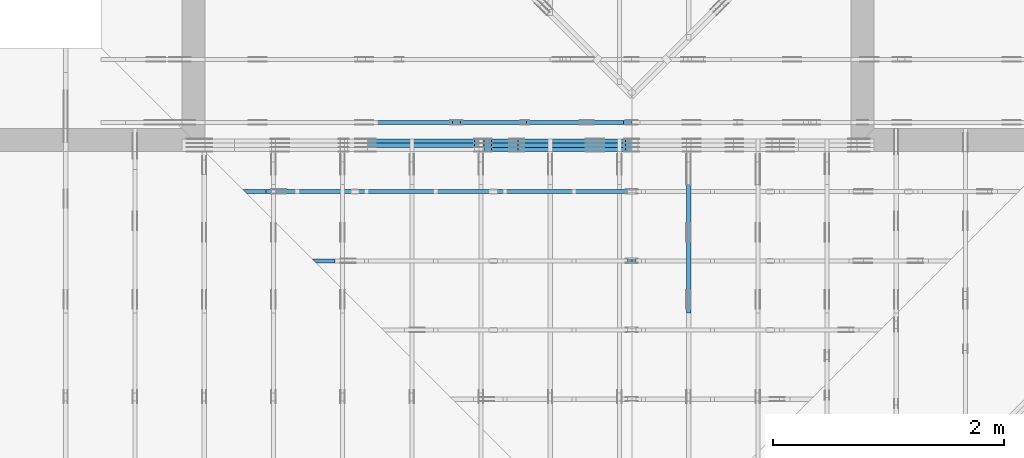
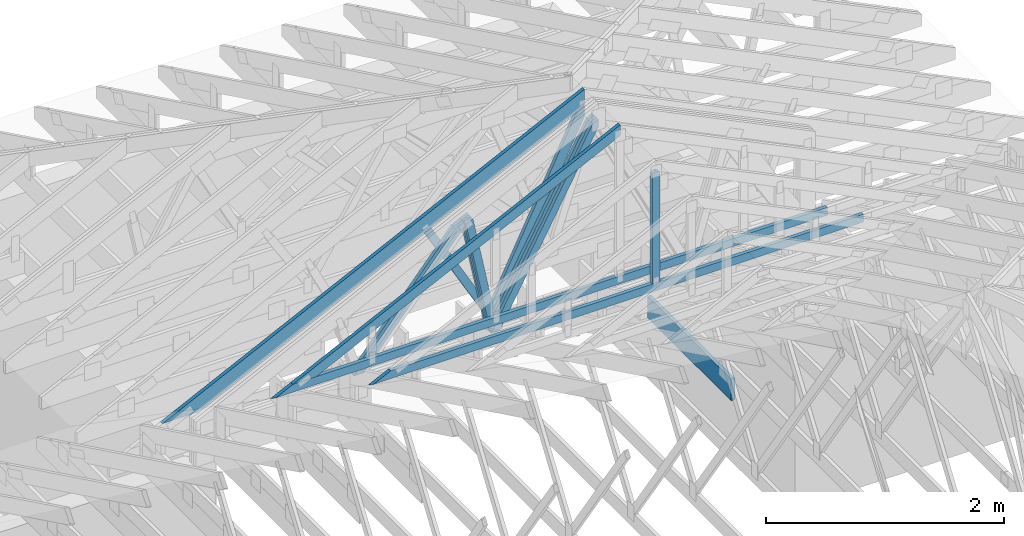
# One storey, part 23 of 159: 16 members, 5 elements without a shape of their own.
"""IFC2X3 building model written with IfcOpenShell, lengths in millimetres."""

from ifc_helpers import new_model, si_unit, frame, origin, origin_with_axes, origin_2d, place, context, project, spatial, faceted_brep, element, aggregate, save


model = new_model("IFC2X3")

# Units and contexts
model_context = context("Model", 3, precision=1e-05, world=origin())
plan_context = context("Plan", 2, precision=1e-05, world=origin_2d())
ifc_project = project(units=[si_unit("LENGTHUNIT", "METRE", prefix="MILLI"), si_unit("AREAUNIT", "SQUARE_METRE"), si_unit("VOLUMEUNIT", "CUBIC_METRE"), si_unit("SOLIDANGLEUNIT", "STERADIAN"), si_unit("PLANEANGLEUNIT", "RADIAN"), si_unit("MASSUNIT", "GRAM"), si_unit("TIMEUNIT", "SECOND"), si_unit("THERMODYNAMICTEMPERATUREUNIT", "DEGREE_CELSIUS"), si_unit("LUMINOUSINTENSITYUNIT", "LUMEN")], contexts=[model_context, plan_context])

# Site, building, storey
site_placement = place(None, origin_with_axes())
site = spatial("IfcSite", under=ifc_project, at=site_placement, CompositionType="ELEMENT")
building_placement = place(site_placement, origin_with_axes())
building = spatial("IfcBuilding", under=site, at=building_placement, Name="Plan 1", CompositionType="ELEMENT")
storey_placement = place(building_placement, origin_with_axes())
storey = spatial("IfcBuildingStorey", under=building, at=storey_placement, Name="Etasje 1", CompositionType="ELEMENT", Elevation=0.0)

# Assembly, members
assembly_1_placement = place(storey_placement, frame((10700.012663101485, 8801.999999990367, 0.0), z_axis=(0.0, -1.0, 6.123031769111886e-17), x_axis=(1.0, 0.0, 0.0)))
assembly_1 = element("IfcElementAssembly", 1, at=assembly_1_placement, inside=storey, Name="T8 (1)", AssemblyPlace="FACTORY", PredefinedType="TRUSS")
member_1_placement = place(assembly_1_placement, frame((3867.9698869017257, 2216.40711603102, -35.99999999999999), z_axis=(0.0, 0.0, 1.0), x_axis=(-0.47951342350891896, -0.8775345444338677, 0.0)))
member_1 = element("IfcMember", 2, at=member_1_placement, Name="T8-D13", context=model_context, shape_type="Brep", body=[
    faceted_brep([(2063.0556535185974, 73.00006895054366, 36.0), (70.69479800117142, 73.00006895054366, 36.0), (3.076359143960872e-05, 36.500133303005896, 36.0), (51.46241365079777, 0.0, 36.0), (2102.9451764367454, 0.0, 36.0), (70.69479800117142, 73.00006895054366, 8.657329881442401e-15), (2063.0556535185974, 73.00006895054366, 2.526431061588051e-13), (2102.9451764367454, 0.0, 2.575280024804559e-13), (51.46241365079777, 0.0, 6.3021198739802395e-15), (3.076359143960872e-05, 36.500133303005896, 3.767328954334053e-21), (-3.552713678800501e-15, 36.500116492776684, 7.372614494505173e-31), (-1.7763568394002505e-15, 36.500116492776684, 36.0), (70.6948916179522, 73.00011649299769, 36.0), (70.6948916179522, 73.00011649299769, 9.766347878213117e-32), (51.46243155100409, 0.00011649299766247623, 1.4419901279364019e-30), (51.46243155100409, 0.00011649299766602894, 36.0), (3.552713678800501e-15, 36.50011649277667, 36.0), (3.552713678800501e-15, 36.50011649277667, -5.245676865394483e-31), (2102.9452024154884, 0.00011649299727898752, 5.219559490170898e-29), (2102.9452024154884, 0.00011649299728119181, 36.0), (51.4624315510041, 0.00011649299765803063, 36.0), (51.4624315510041, 0.00011649299765582634, 1.277309841038534e-30), (2063.055627539853, 73.00011649299802, -2.2392547899643435e-29), (2063.055627539853, 73.00011649299802, 36.0), (2102.945202415488, 0.0001164929980177476, 36.0), (2102.945202415488, 0.0001164929980177476, -9.514431806615905e-30), (70.69489161795218, 73.00011649299768, -7.888609052210118e-31), (70.69489161795218, 73.00011649299768, 36.0), (2063.0556275398535, 73.00011649299799, 36.0), (2063.0556275398535, 73.00011649299799, -8.67746995743113e-30)], [[[0, 1, 2, 3, 4]], [[5, 6, 7, 8, 9]], [[10, 11, 12, 13]], [[14, 15, 16, 17]], [[18, 19, 20, 21]], [[22, 23, 24, 25]], [[26, 27, 28, 29]]]),
])
member_2_placement = place(assembly_1_placement, frame((3867.9698869017257, 2216.40711603102, -71.99999999999999), z_axis=(0.0, 0.0, 1.0), x_axis=(-0.47951342350891896, -0.8775345444338677, 0.0)))
member_2 = element("IfcMember", 3, at=member_2_placement, Name="T8-D13", context=model_context, shape_type="Brep", body=[
    faceted_brep([(2063.0556535185974, 73.00006895054366, 36.0), (70.69479800117142, 73.00006895054366, 36.0), (3.076359143960872e-05, 36.500133303005896, 36.0), (51.46241365079777, 0.0, 36.0), (2102.9451764367454, 0.0, 36.0), (70.69479800117142, 73.00006895054366, 8.657329881442401e-15), (2063.0556535185974, 73.00006895054366, 2.526431061588051e-13), (2102.9451764367454, 0.0, 2.575280024804559e-13), (51.46241365079777, 0.0, 6.3021198739802395e-15), (3.076359143960872e-05, 36.500133303005896, 3.767328954334053e-21), (-3.552713678800501e-15, 36.500116492776684, 7.372614494505173e-31), (-1.7763568394002505e-15, 36.500116492776684, 36.0), (70.6948916179522, 73.00011649299769, 36.0), (70.6948916179522, 73.00011649299769, 9.766347878213117e-32), (51.46243155100409, 0.00011649299766247623, 1.4419901279364019e-30), (51.46243155100409, 0.00011649299766602894, 36.0), (3.552713678800501e-15, 36.50011649277667, 36.0), (3.552713678800501e-15, 36.50011649277667, -5.245676865394483e-31), (2102.9452024154884, 0.00011649299727898752, 5.219559490170898e-29), (2102.9452024154884, 0.00011649299728119181, 36.0), (51.4624315510041, 0.00011649299765803063, 36.0), (51.4624315510041, 0.00011649299765582634, 1.277309841038534e-30), (2063.055627539853, 73.00011649299802, -2.2392547899643435e-29), (2063.055627539853, 73.00011649299802, 36.0), (2102.945202415488, 0.0001164929980177476, 36.0), (2102.945202415488, 0.0001164929980177476, -9.514431806615905e-30), (70.69489161795218, 73.00011649299768, -7.888609052210118e-31), (70.69489161795218, 73.00011649299768, 36.0), (2063.0556275398535, 73.00011649299799, 36.0), (2063.0556275398535, 73.00011649299799, -8.67746995743113e-30)], [[[0, 1, 2, 3, 4]], [[5, 6, 7, 8, 9]], [[10, 11, 12, 13]], [[14, 15, 16, 17]], [[18, 19, 20, 21]], [[22, 23, 24, 25]], [[26, 27, 28, 29]]]),
])
member_3_placement = place(assembly_1_placement, frame((3867.9698869017257, 2216.40711603102, -107.99999999999999), z_axis=(0.0, 0.0, 1.0), x_axis=(-0.47951342350891896, -0.8775345444338677, 0.0)))
member_3 = element("IfcMember", 4, at=member_3_placement, Name="T8-D13", context=model_context, shape_type="Brep", body=[
    faceted_brep([(2063.0556535185974, 73.00006895054366, 36.0), (70.69479800117142, 73.00006895054366, 36.0), (3.076359143960872e-05, 36.500133303005896, 36.0), (51.46241365079777, 0.0, 36.0), (2102.9451764367454, 0.0, 36.0), (70.69479800117142, 73.00006895054366, 8.657329881442401e-15), (2063.0556535185974, 73.00006895054366, 2.526431061588051e-13), (2102.9451764367454, 0.0, 2.575280024804559e-13), (51.46241365079777, 0.0, 6.3021198739802395e-15), (3.076359143960872e-05, 36.500133303005896, 3.767328954334053e-21), (-3.552713678800501e-15, 36.500116492776684, 7.372614494505173e-31), (-1.7763568394002505e-15, 36.500116492776684, 36.0), (70.6948916179522, 73.00011649299769, 36.0), (70.6948916179522, 73.00011649299769, 9.766347878213117e-32), (51.46243155100409, 0.00011649299766247623, 1.4419901279364019e-30), (51.46243155100409, 0.00011649299766602894, 36.0), (3.552713678800501e-15, 36.50011649277667, 36.0), (3.552713678800501e-15, 36.50011649277667, -5.245676865394483e-31), (2102.9452024154884, 0.00011649299727898752, 5.219559490170898e-29), (2102.9452024154884, 0.00011649299728119181, 36.0), (51.4624315510041, 0.00011649299765803063, 36.0), (51.4624315510041, 0.00011649299765582634, 1.277309841038534e-30), (2063.055627539853, 73.00011649299802, -2.2392547899643435e-29), (2063.055627539853, 73.00011649299802, 36.0), (2102.945202415488, 0.0001164929980177476, 36.0), (2102.945202415488, 0.0001164929980177476, -9.514431806615905e-30), (70.69489161795218, 73.00011649299768, -7.888609052210118e-31), (70.69489161795218, 73.00011649299768, 36.0), (2063.0556275398535, 73.00011649299799, 36.0), (2063.0556275398535, 73.00011649299799, -8.67746995743113e-30)], [[[0, 1, 2, 3, 4]], [[5, 6, 7, 8, 9]], [[10, 11, 12, 13]], [[14, 15, 16, 17]], [[18, 19, 20, 21]], [[22, 23, 24, 25]], [[26, 27, 28, 29]]]),
])
member_4_placement = place(assembly_1_placement, frame((2613.0890125639594, 1591.6873886170583, -36.0), z_axis=(0.0, 0.0, 1.0), x_axis=(0.19793262391770408, -0.9802156274968548, 0.0)))
member_4 = element("IfcMember", 5, at=member_4_placement, Name="T8-D43", context=model_context, shape_type="Brep", body=[
    faceted_brep([(1158.542023059712, 72.99999173461038, 36.0), (0.0, 72.99999173461038, 36.0), (18.99321109125617, 0.0, 36.0), (1245.3253813427452, 0.0, 36.0), (0.0, 72.99999173461038, 0.0), (1158.542023059712, 72.99999173461038, 1.4187579226091543e-13), (1245.3253813427452, 0.0, 1.5250333745686008e-13), (18.99321109125617, 0.0, 2.3259206981841956e-15), (18.993194004226893, 4.962709226674633e-06, 0.0), (18.993194004226893, 4.9627092275628115e-06, 36.0), (8.38193204089066e-06, 73.00000496270786, 36.0), (8.381932037337947e-06, 73.00000496270786, 5.9164567891575885e-31), (1245.3253706192897, 4.962708997919629e-06, 1.400674159853659e-29), (1245.3253706192897, 4.9627090001239205e-06, 36.0), (18.993194004226893, 4.962709225390047e-06, 36.0), (18.993194004226893, 4.962709223185755e-06, 2.1362508042295805e-31), (1158.5420338777596, 73.00000496270889, 6.310887241768095e-30), (1158.5420338777596, 73.00000496270889, 36.0), (1245.3253706192897, 4.962709340361471e-06, 36.0), (1245.3253706192897, 4.962709340361471e-06, 6.310887241768095e-30), (8.381932047996088e-06, 73.00000496270786, 0.0), (8.381932047996088e-06, 73.00000496270786, 36.0), (1158.5420338777596, 73.00000496270907, 36.0), (1158.5420338777596, 73.00000496270908, 1.8932661725304283e-29)], [[[0, 1, 2, 3]], [[4, 5, 6, 7]], [[8, 9, 10, 11]], [[12, 13, 14, 15]], [[16, 17, 18, 19]], [[20, 21, 22, 23]]]),
])
member_5_placement = place(assembly_1_placement, frame((2613.0890125639594, 1591.6873886170583, -72.0), z_axis=(0.0, 0.0, 1.0), x_axis=(0.19793262391770408, -0.9802156274968548, 0.0)))
member_5 = element("IfcMember", 6, at=member_5_placement, Name="T8-D43", context=model_context, shape_type="Brep", body=[
    faceted_brep([(1158.542023059712, 72.99999173461038, 36.0), (0.0, 72.99999173461038, 36.0), (18.99321109125617, 0.0, 36.0), (1245.3253813427452, 0.0, 36.0), (0.0, 72.99999173461038, 0.0), (1158.542023059712, 72.99999173461038, 1.4187579226091543e-13), (1245.3253813427452, 0.0, 1.5250333745686008e-13), (18.99321109125617, 0.0, 2.3259206981841956e-15), (18.993194004226893, 4.962709226674633e-06, 0.0), (18.993194004226893, 4.9627092275628115e-06, 36.0), (8.38193204089066e-06, 73.00000496270786, 36.0), (8.381932037337947e-06, 73.00000496270786, 5.9164567891575885e-31), (1245.3253706192897, 4.962708997919629e-06, 1.400674159853659e-29), (1245.3253706192897, 4.9627090001239205e-06, 36.0), (18.993194004226893, 4.962709225390047e-06, 36.0), (18.993194004226893, 4.962709223185755e-06, 2.1362508042295805e-31), (1158.5420338777596, 73.00000496270889, 6.310887241768095e-30), (1158.5420338777596, 73.00000496270889, 36.0), (1245.3253706192897, 4.962709340361471e-06, 36.0), (1245.3253706192897, 4.962709340361471e-06, 6.310887241768095e-30), (8.381932047996088e-06, 73.00000496270786, 0.0), (8.381932047996088e-06, 73.00000496270786, 36.0), (1158.5420338777596, 73.00000496270907, 36.0), (1158.5420338777596, 73.00000496270908, 1.8932661725304283e-29)], [[[0, 1, 2, 3]], [[4, 5, 6, 7]], [[8, 9, 10, 11]], [[12, 13, 14, 15]], [[16, 17, 18, 19]], [[20, 21, 22, 23]]]),
])
member_6_placement = place(assembly_1_placement, frame((2613.0890125639594, 1591.6873886170583, -108.0), z_axis=(0.0, 0.0, 1.0), x_axis=(0.19793262391770408, -0.9802156274968548, 0.0)))
member_6 = element("IfcMember", 7, at=member_6_placement, Name="T8-D43", context=model_context, shape_type="Brep", body=[
    faceted_brep([(1158.542023059712, 72.99999173461038, 36.0), (0.0, 72.99999173461038, 36.0), (18.99321109125617, 0.0, 36.0), (1245.3253813427452, 0.0, 36.0), (0.0, 72.99999173461038, 0.0), (1158.542023059712, 72.99999173461038, 1.4187579226091543e-13), (1245.3253813427452, 0.0, 1.5250333745686008e-13), (18.99321109125617, 0.0, 2.3259206981841956e-15), (18.993194004226893, 4.962709226674633e-06, 0.0), (18.993194004226893, 4.9627092275628115e-06, 36.0), (8.38193204089066e-06, 73.00000496270786, 36.0), (8.381932037337947e-06, 73.00000496270786, 5.9164567891575885e-31), (1245.3253706192897, 4.962708997919629e-06, 1.400674159853659e-29), (1245.3253706192897, 4.9627090001239205e-06, 36.0), (18.993194004226893, 4.962709225390047e-06, 36.0), (18.993194004226893, 4.962709223185755e-06, 2.1362508042295805e-31), (1158.5420338777596, 73.00000496270889, 6.310887241768095e-30), (1158.5420338777596, 73.00000496270889, 36.0), (1245.3253706192897, 4.962709340361471e-06, 36.0), (1245.3253706192897, 4.962709340361471e-06, 6.310887241768095e-30), (8.381932047996088e-06, 73.00000496270786, 0.0), (8.381932047996088e-06, 73.00000496270786, 36.0), (1158.5420338777596, 73.00000496270907, 36.0), (1158.5420338777596, 73.00000496270908, 1.8932661725304283e-29)], [[[0, 1, 2, 3]], [[4, 5, 6, 7]], [[8, 9, 10, 11]], [[12, 13, 14, 15]], [[16, 17, 18, 19]], [[20, 21, 22, 23]]]),
])
member_7_placement = place(assembly_1_placement, frame((2588.98150183582, 1596.6429683989554, -72.0), z_axis=(0.0, 0.0, 1.0), x_axis=(-0.6458357364032298, -0.7634763922902252, 0.0)))
member_7 = element("IfcMember", 8, at=member_7_placement, Name="T8-D24", context=model_context, shape_type="Brep", body=[
    faceted_brep([(1543.5932006244534, 72.99998709430429, 36.0), (28.88351769405017, 72.99998709430429, 36.0), (1.4494809875031933e-05, 36.500010319543776, 36.0), (82.86761682691758, 1.7008971553877927e-05, 36.0), (1605.3449359283989, 1.7008971553877927e-05, 36.0), (28.88351769405017, 72.99998709430429, 3.5370939288874897e-15), (1543.5932006244534, 72.99998709430429, 1.890294041201725e-13), (1605.3449359283989, 1.7008971553877927e-05, 1.9659156086144943e-13), (82.86761682691758, 1.7008971553877927e-05, 1.0148021009236142e-14), (1.4494809875031933e-05, 36.500010319543776, 1.7750436270411443e-21), (-3.552713678800501e-15, 36.499999999876884, 3.944304526105059e-31), (-3.552713678800501e-15, 36.499999999876884, 36.0), (28.883460935114723, 73.00000000000034, 36.0), (28.883460935114723, 73.00000000000034, 3.944304526105059e-31), (82.8676636786472, -3.552713678800501e-15, 0.0), (82.8676636786472, 0.0, 36.0), (1.7763568394002505e-15, 36.49999999987688, 36.0), (0.0, 36.49999999987688, 0.0), (1605.3449468455124, -3.4439067704007967e-13, 7.67758000929694e-29), (1605.3449468455124, -3.421863856031994e-13, 36.0), (82.8676636786472, -6.252108242574337e-14, 36.0), (82.8676636786472, -6.472537386262365e-14, 3.963155204284888e-30), (1543.5931897073374, 73.00000000000114, 1.262177448353619e-29), (1543.5931897073374, 73.00000000000114, 36.0), (1605.3449468455124, 9.094947017729282e-13, 36.0), (1605.3449468455124, 9.094947017729282e-13, 0.0), (28.883460935114726, 73.00000000000036, 7.888609052210118e-31), (28.883460935114726, 73.00000000000036, 36.0), (1543.5931897073374, 73.0000000000016, 36.0), (1543.5931897073374, 73.0000000000016, 2.8398992587956425e-29)], [[[0, 1, 2, 3, 4]], [[5, 6, 7, 8, 9]], [[10, 11, 12, 13]], [[14, 15, 16, 17]], [[18, 19, 20, 21]], [[22, 23, 24, 25]], [[26, 27, 28, 29]]]),
])
member_8_placement = place(assembly_1_placement, frame((2588.98150183582, 1596.6429683989554, -108.0), z_axis=(0.0, 0.0, 1.0), x_axis=(-0.6458357364032298, -0.7634763922902252, 0.0)))
member_8 = element("IfcMember", 9, at=member_8_placement, Name="T8-D24", context=model_context, shape_type="Brep", body=[
    faceted_brep([(1543.5932006244534, 72.99998709430429, 36.0), (28.88351769405017, 72.99998709430429, 36.0), (1.4494809875031933e-05, 36.500010319543776, 36.0), (82.86761682691758, 1.7008971553877927e-05, 36.0), (1605.3449359283989, 1.7008971553877927e-05, 36.0), (28.88351769405017, 72.99998709430429, 3.5370939288874897e-15), (1543.5932006244534, 72.99998709430429, 1.890294041201725e-13), (1605.3449359283989, 1.7008971553877927e-05, 1.9659156086144943e-13), (82.86761682691758, 1.7008971553877927e-05, 1.0148021009236142e-14), (1.4494809875031933e-05, 36.500010319543776, 1.7750436270411443e-21), (-3.552713678800501e-15, 36.499999999876884, 3.944304526105059e-31), (-3.552713678800501e-15, 36.499999999876884, 36.0), (28.883460935114723, 73.00000000000034, 36.0), (28.883460935114723, 73.00000000000034, 3.944304526105059e-31), (82.8676636786472, -3.552713678800501e-15, 0.0), (82.8676636786472, 0.0, 36.0), (1.7763568394002505e-15, 36.49999999987688, 36.0), (0.0, 36.49999999987688, 0.0), (1605.3449468455124, -3.4439067704007967e-13, 7.67758000929694e-29), (1605.3449468455124, -3.421863856031994e-13, 36.0), (82.8676636786472, -6.252108242574337e-14, 36.0), (82.8676636786472, -6.472537386262365e-14, 3.963155204284888e-30), (1543.5931897073374, 73.00000000000114, 1.262177448353619e-29), (1543.5931897073374, 73.00000000000114, 36.0), (1605.3449468455124, 9.094947017729282e-13, 36.0), (1605.3449468455124, 9.094947017729282e-13, 0.0), (28.883460935114726, 73.00000000000036, 7.888609052210118e-31), (28.883460935114726, 73.00000000000036, 36.0), (1543.5931897073374, 73.0000000000016, 36.0), (1543.5931897073374, 73.0000000000016, 2.8398992587956425e-29)], [[[0, 1, 2, 3, 4]], [[5, 6, 7, 8, 9]], [[10, 11, 12, 13]], [[14, 15, 16, 17]], [[18, 19, 20, 21]], [[22, 23, 24, 25]], [[26, 27, 28, 29]]]),
])
aggregate(assembly_1, [member_1, member_2, member_3, member_4, member_5, member_6, member_7, member_8])

assembly_2_placement = place(storey_placement, frame((10000.012663278096, 9072.000080051337, 1.1021457184401395e-15), z_axis=(9.811600543477555e-09, 1.0, 6.123031769111886e-17), x_axis=(-1.0, 9.811600543477555e-09, 0.0)))
assembly_2 = element("IfcElementAssembly", 10, at=assembly_2_placement, inside=storey, Name="T9 (79)", AssemblyPlace="FACTORY", PredefinedType="TRUSS")
member_9_placement = place(assembly_2_placement, frame((-4664.878943537051, 2230.5483602309946, -36.0), z_axis=(0.0, 0.0, 1.0), x_axis=(0.8987940462991668, -0.4383711467890778, 0.0)))
member_9 = element("IfcMember", 11, at=member_9_placement, Name="T9-O15", context=model_context, shape_type="Brep", body=[
    faceted_brep([(4545.394730246214, 148.00002383615333, 36.0), (3.646540790214203e-05, 148.00002383615333, 36.0), (72.18443847530398, 0.0, 36.0), (4241.949758533083, 0.0, 36.0), (3.646540790214203e-05, 148.00002383615333, 4.465577021168786e-21), (4545.394730246214, 148.00002383615333, 5.566319267290264e-13), (4241.949758533083, 0.0, 5.194718626894912e-13), (72.18443847530398, 0.0, 8.839752200395772e-15), (72.18442310739556, 3.150888391800777e-05, 0.0), (72.18442310739556, 3.150888391800777e-05, 36.0), (-7.105427357601002e-15, 148.00003150816266, 36.0), (-7.105427357601002e-15, 148.00003150816266, 7.888609052210118e-31), (4241.949777422341, 3.150811647390567e-05, 2.0911757153885425e-28), (4241.949777422341, 3.1508116476109963e-05, 36.0), (72.18442310739556, 3.150888386564794e-05, 36.0), (72.18442310739556, 3.150888386344365e-05, 3.558512546379876e-30), (4545.394745976379, 148.00003150826842, -5.048709793414476e-29), (4545.394745976379, 148.00003150826842, 36.0), (4241.949777422341, 3.1508120400758344e-05, 36.0), (4241.949777422341, 3.1508120400758344e-05, -2.524354896707238e-29), (0.0, 148.0000315081627, 0.0), (0.0, 148.0000315081627, 36.0), (4545.39474597638, 148.0000315082684, 36.0), (4545.39474597638, 148.0000315082684, 7.888609052210118e-30)], [[[0, 1, 2, 3]], [[4, 5, 6, 7]], [[8, 9, 10, 11]], [[12, 13, 14, 15]], [[16, 17, 18, 19]], [[20, 21, 22, 23]]]),
])
member_10_placement = place(assembly_2_placement, frame((-4644.001488321772, 2177.3439269112123, -36.0), z_axis=(0.0, 0.0, 1.0), x_axis=(0.4400179470942461, -0.8979889789050672, 0.0)))
member_10 = element("IfcMember", 12, at=member_10_placement, Name="T9-D6", context=model_context, shape_type="Brep", body=[
    faceted_brep([(2059.563933297521, 98.00006300901259, 36.0), (62.954661424061214, 98.00006300901259, 36.0), (3.1480658890359337e-05, 49.000016150941974, 36.0), (99.99930369282492, 0.0, 36.0), (2011.5435371806498, 0.0, 36.0), (62.954661424061214, 98.00006300901259, 7.709467838264188e-15), (2059.563933297521, 98.00006300901259, 2.522155078819551e-13), (2011.5435371806498, 0.0, 2.463348996621763e-13), (99.99930369282492, 0.0, 1.2245978268004691e-14), (3.1480658890359337e-05, 49.000016150941974, 3.855141489964895e-21), (-7.105427357601002e-15, 49.00003157658422, 7.888609052210118e-31), (-7.105427357601002e-15, 49.00003157658422, 36.0), (62.954664211484186, 98.00003157638096, 36.0), (62.954664211484186, 98.00003157638096, 1.5777218104420236e-30), (99.99923925161966, 3.15763813532044e-05, 1.9721522630525295e-30), (99.99923925161966, 3.15763813532044e-05, 36.0), (-3.552713678800501e-15, 49.00003157658421, 36.0), (-3.552713678800501e-15, 49.00003157658421, 0.0), (2011.5435525811163, 3.1576382686892026e-05, 5.973484439974737e-29), (2011.5435525811163, 3.157638268909632e-05, 36.0), (99.99923925161966, 3.157638134243731e-05, 36.0), (99.99923925161966, 3.1576381340233016e-05, 2.9695797203467188e-30), (2059.5639178954148, 98.0000315763831, -5.048709793414476e-29), (2059.5639178954148, 98.0000315763831, 36.0), (2011.5435525811156, 3.1576383889841964e-05, 36.0), (2011.5435525811156, 3.1576383889841964e-05, -3.7865323450608567e-29), (62.95466421148421, 98.00003157638095, 0.0), (62.95466421148421, 98.00003157638093, 36.0), (2059.563917895415, 98.00003157638304, 36.0), (2059.563917895415, 98.00003157638304, 1.735493991486226e-29)], [[[0, 1, 2, 3, 4]], [[5, 6, 7, 8, 9]], [[10, 11, 12, 13]], [[14, 15, 16, 17]], [[18, 19, 20, 21]], [[22, 23, 24, 25]], [[26, 27, 28, 29]]]),
])
member_11_placement = place(assembly_2_placement, frame((-3110.819209204306, 1477.3607732588273, -36.0), z_axis=(0.0, 0.0, 1.0), x_axis=(-0.4904855667803157, -0.8714493150953715, 0.0)))
member_11 = element("IfcMember", 13, at=member_11_placement, Name="T9-D44", context=model_context, shape_type="Brep", body=[
    faceted_brep([(1228.4767889479199, 73.0001438261238, 36.0), (5.650484354191576e-06, 73.0001438261238, 36.0), (4.301839151545437, 0.0, 36.0), (1178.2631640479285, 0.0, 36.0), (5.650484354191576e-06, 73.0001438261238, 6.919619042316936e-22), (1228.4767889479199, 73.0001438261238, 1.5044004812689342e-13), (1178.2631640479285, 0.0, 1.4429085571679513e-13), (4.301839151545437, 0.0, 5.268059558104406e-16), (4.301840855415321, 0.0001133224691329815, 0.0), (4.301840855415323, 0.00011332246913309252, 36.0), (3.552713678800501e-14, 73.00011332246959, 36.0), (3.375077994860476e-14, 73.00011332246959, -2.0214560696288428e-30), (1178.2631286881144, 0.00011332246787337006, 2.1437757924420756e-29), (1178.2631286881144, 0.00011332246787557435, 36.0), (4.301840855415321, 0.0001133224691339075, 36.0), (4.301840855415321, 0.00011332246913170321, 7.826949201334345e-32), (1228.4768061165641, 73.00011332246788, 2.524354896707238e-29), (1228.4768061165641, 73.00011332246788, 36.0), (1178.2631286881146, 0.00011332246788242628, 36.0), (1178.2631286881146, 0.00011332246788242628, 2.524354896707238e-29), (0.0, 73.00011332246959, 0.0), (0.0, 73.00011332246959, 36.0), (1228.476806116564, 73.00011332246815, 36.0), (1228.476806116564, 73.00011332246815, -4.733165431326071e-30)], [[[0, 1, 2, 3]], [[4, 5, 6, 7]], [[8, 9, 10, 11]], [[12, 13, 14, 15]], [[16, 17, 18, 19]], [[20, 21, 22, 23]]]),
])
aggregate(assembly_2, [member_9, member_10, member_11])

# Assembly, member
assembly_3_placement = place(storey_placement, frame((15075.02226140475, -699.9989301294845, 1.1021457184401395e-15), z_axis=(-1.0, 1.836909530733566e-16, 6.123031769111886e-17), x_axis=(-1.836909530733566e-16, -1.0, 0.0)))
assembly_3 = element("IfcElementAssembly", 14, at=assembly_3_placement, inside=storey, Name="T7 (103)", AssemblyPlace="FACTORY", PredefinedType="TRUSS")
member_12_placement = place(assembly_3_placement, frame((-9501.9990234375, 0.0, -36.0), z_axis=(0.0, 0.0, 1.0), x_axis=(1.0, 0.0, 0.0)))
member_12 = element("IfcMember", 15, at=member_12_placement, Name="T7-U19", context=model_context, shape_type="Brep", body=[
    faceted_brep([(1402.0, 223.0, 36.0), (0.0, 223.0, 36.0), (0.0, 0.0, 36.0), (1402.0, 0.0, 36.0), (0.0, 223.0, 0.0), (1402.0, 223.0, 1.716898108058973e-13), (1402.0, 0.0, 1.716898108058973e-13), (0.0, 0.0, 0.0), (9.331764886155725e-05, 0.0, 0.0), (9.331764886376154e-05, -2.6993892992798474e-31, 36.0), (9.331764889107026e-05, 223.0, 36.0), (9.331764888886597e-05, 223.0, -1.6721217180559947e-30), (1402.0000933176489, -2.575347333504538e-13, 1.576893353954587e-29), (1402.0000933176489, -2.553304419135735e-13, 36.0), (9.331764886155725e-05, 2.204274295272421e-15, 36.0), (9.331764886155725e-05, -1.714160785794428e-20, 1.0495860948785078e-36), (1402.0000933176489, 223.0, 0.0), (1402.0000933176489, 223.0, 36.0), (1402.0000933176489, 0.0, 36.0), (1402.0000933176489, 0.0, 0.0), (9.331764886155725e-05, 223.0, 0.0), (9.331764886155725e-05, 223.0, 36.0), (1402.0000933176489, 222.99999999999991, 36.0), (1402.0000933176489, 222.99999999999991, -4.733165431326071e-30)], [[[0, 1, 2, 3]], [[4, 5, 6, 7]], [[8, 9, 10, 11]], [[12, 13, 14, 15]], [[16, 17, 18, 19]], [[20, 21, 22, 23]]]),
])
aggregate(assembly_3, [member_12])

# Assembly, members
assembly_4_placement = place(storey_placement, frame((11246.01259527543, 8436.00006782605, 727.7147722720857), z_axis=(0.0, -1.0, 6.123031769111886e-17), x_axis=(1.0, 0.0, 0.0)))
assembly_4 = element("IfcElementAssembly", 16, at=assembly_4_placement, inside=storey, Name="Tr1 (1)", AssemblyPlace="FACTORY", PredefinedType="TRUSS")
member_13_placement = place(assembly_4_placement, frame((225.890181795153, 1.1390106487699683, -36.0), z_axis=(0.0, 0.0, 1.0), x_axis=(0.898794046299167, 0.4383711467890774, 0.0)))
member_13 = element("IfcMember", 17, at=member_13_placement, Name="Tr1-O81", context=model_context, shape_type="Brep", body=[
    faceted_brep([(3528.1388486489927, 98.00000249180584, 36.0), (2.616054388226985e-06, 98.00000249180584, 36.0), (200.92978933743032, 0.0, 36.0), (3480.3410891875596, 0.0, 36.0), (2.616054388226985e-06, 98.00000249180584, 3.2036368257676777e-22), (3528.1388486489927, 98.00000249180584, 4.320581251223123e-13), (3480.3410891875596, 0.0, 4.2620478112881786e-13), (200.92978933743032, 0.0, 2.460598966948089e-14), (200.92977647399948, 2.0519620278491857e-06, 3.711943346041881e-30), (200.92977647399948, 2.0519620278491857e-06, 36.0), (7.105427357601002e-15, 98.0000020515858, 36.0), (7.105427357601002e-15, 98.0000020515858, -9.212427761506589e-31), (3480.3411302193517, 2.0538865765484233e-06, 1.991956244730974e-28), (3480.3411302193517, 2.0538865787527147e-06, 36.0), (200.9297764739995, 2.051961884868665e-06, 36.0), (200.9297764739995, 2.0519618826643737e-06, 1.1500117585902466e-29), (3528.1389238982865, 98.00000205282413, 5.048709793414476e-29), (3528.1389238982865, 98.00000205282413, 36.0), (3480.341130219352, 2.0538896023936104e-06, 36.0), (3480.341130219352, 2.0538896023936104e-06, 2.524354896707238e-29), (0.0, 98.00000205158578, 0.0), (0.0, 98.00000205158578, 36.0), (3528.138923898286, 98.00000205282413, 36.0), (3528.138923898286, 98.00000205282413, 0.0)], [[[0, 1, 2, 3]], [[4, 5, 6, 7]], [[8, 9, 10, 11]], [[12, 13, 14, 15]], [[16, 17, 18, 19]], [[20, 21, 22, 23]]]),
])
member_14_placement = place(assembly_4_placement, frame((5362.000121008605, 89.22083191162922, -36.000001121233524), z_axis=(0.0, 0.0, 1.0), x_axis=(-1.0, 1.2246063538223773e-16, 0.0)))
member_14 = element("IfcMember", 18, at=member_14_placement, Name="Tr1-U43", context=model_context, shape_type="Brep", body=[
    faceted_brep([(8.897483348846437e-05, 98.00000288158914, 3.315600292808085e-05), (8.897483348738926e-05, 80.44164512936932, 36.00000150721327), (5344.000119492412, 80.44164512936905, 36.00000150721314), (5380.0000889748335, 98.00000288113073, 3.315694213057441e-05), (5344.000121010541, 80.44164531762418, 36.000001121233524), (0.00012101054107915843, 80.44164531762418, 36.000001121233524), (0.00012101054107915843, 2.5563936958405975e-06, 36.000001121233524), (5179.070311440229, 2.5563936958405975e-06, 36.000001121233524), (8.897483348846436e-05, 0.0, 0.0), (8.897483349066865e-05, -2.6993894570620914e-31, 36.0000021042392), (8.897483350051959e-05, 80.44164531762358, 36.000001121233524), (8.89748335004655e-05, 98.00000286803692, 3.308544472702124e-05), (5179.0703125, 2.8811300446535956e-06, 1.1212335238042215e-06), (5179.0703125, 2.881130046857887e-06, 36.000001121233524), (4.0490840811628856e-31, 2.8811309982062485e-06, 36.000001121233524), (1.3224311446750734e-38, 2.881130996001957e-06, 1.1212335238042215e-06), (5380.000088974831, 98.00000288113256, 3.3156942265577534e-05), (5344.000120624561, 80.44164512937164, 36.00000263936413), (5179.070315967953, 4.572567377181258e-06, 36.00000263936411), (5179.070315967953, 4.572567377181258e-06, 1.1212319179776387e-06), (8.897483348846436e-05, 98.00000288158863, 1.1212335238042323e-06), (5380.0000889748335, 98.00000288158863, 1.1212341826424506e-06), (5179.070309922099, 2.881131010212812e-06, 1.1212341580364624e-06), (8.897483348846436e-05, 2.881131010212812e-06, 1.1212335238042323e-06)], [[[0, 1, 2, 3]], [[4, 5, 6, 7]], [[8, 9, 10, 11]], [[12, 13, 14, 15]], [[16, 17, 18, 19]], [[20, 21, 22, 23]]]),
])
aggregate(assembly_4, [member_13, member_14])

assembly_5_placement = place(storey_placement, frame((11846.012601162385, 7836.000061939094, 1020.3543282828622), z_axis=(0.0, -1.0, 6.123031769111886e-17), x_axis=(1.0, 0.0, 0.0)))
assembly_5 = element("IfcElementAssembly", 19, at=assembly_5_placement, inside=storey, Name="Tr2 (1)", AssemblyPlace="FACTORY", PredefinedType="TRUSS")
member_15_placement = place(assembly_5_placement, frame((4762.000121008605, 89.22083191166267, -36.00000112118894), z_axis=(0.0, 0.0, 1.0), x_axis=(-1.0, 1.2246063538223773e-16, 0.0)))
member_15 = element("IfcMember", 20, at=member_15_placement, Name="Tr2-U44", context=model_context, shape_type="Brep", body=[
    faceted_brep([(8.897483348846436e-05, 98.00000288162141, 3.3155896673520147e-05), (8.897483348738925e-05, 80.4416451294009, 36.00000150710382), (4744.000119492412, 80.44164512940065, 36.000001507103704), (4780.0000889748335, 98.00000288116415, 3.3156833580960665e-05), (4744.000121010473, 80.44164531762411, 36.00000112118894), (0.0001210104728670558, 80.44164531762411, 36.00000112118894), (0.0001210104728670558, 2.556393624786324e-06, 36.00000112118894), (4579.07031144016, 2.556393624786324e-06, 36.00000112118894), (8.897483439795992e-05, -1.113774058848182e-28, 2.296644996404343e-26), (8.89748334888931e-05, -5.250546457457172e-32, 36.000002104239215), (8.897483349874407e-05, 80.4416453176236, 36.00000112118894), (8.897483440996023e-05, 98.00000286801698, 3.3085390398923664e-05), (4579.0703125, 2.8811635219550387e-06, 1.1211889372475525e-06), (4579.0703125, 2.88116352415933e-06, 36.00000112118894), (4.049084075024997e-31, 2.88116436529312e-06, 36.00000112118894), (1.2610522581987448e-38, 2.8811643630888284e-06, 1.1211889372475525e-06), (4780.000088974832, 98.00000288116667, 3.31568336946475e-05), (4744.000120624561, 80.44164512940529, 36.000002639255555), (4579.070315967952, 4.572600801111548e-06, 36.000002639255534), (4579.070315967952, 4.572600801111548e-06, 1.1211888306661422e-06), (8.897483348846436e-05, 98.00000288162094, 1.1211889372475633e-06), (4780.0000889748335, 98.00000288162094, 1.1211895226094005e-06), (4579.070309922099, 2.881164391510538e-06, 1.1211894980034122e-06), (8.897483348846436e-05, 2.881164391510538e-06, 1.1211889372475633e-06)], [[[0, 1, 2, 3]], [[4, 5, 6, 7]], [[8, 9, 10, 11]], [[12, 13, 14, 15]], [[16, 17, 18, 19]], [[20, 21, 22, 23]]]),
])
member_16_placement = place(assembly_5_placement, frame((2790.5000619390985, 89.22082903049886, -36.0), z_axis=(0.0, 0.0, 1.0), x_axis=(-3.8285889215894375e-16, 1.0, 0.0)))
member_16 = element("IfcMember", 21, at=member_16_placement, Name="Tr2-D46", context=model_context, shape_type="Brep", body=[
    faceted_brep([(1127.1574668679386, 73.00006193909803, 36.0), (3.794208197405169e-06, 73.00006193909803, 36.0), (3.7942081689834595e-06, 6.19390984866186e-05, 36.0), (1127.1574668679386, 6.19390984866186e-05, 36.0), (1144.9597129616886, 36.50006193909803, 36.0), (3.794208197405169e-06, 73.00006193909803, 4.6464114662673185e-22), (1127.1574668679386, 73.00006193909803, 1.3803241956848133e-13), (1144.9597129616886, 36.50006193909803, 1.4021249393635292e-13), (1127.1574668679386, 6.19390984866186e-05, 1.3803241956848133e-13), (3.7942081689834595e-06, 6.19390984866186e-05, 4.646411431461913e-22), (8.093219849501818e-29, 4.547473508864641e-13, -4.955504225290655e-45), (2.20429143688036e-15, 4.547473508864641e-13, 36.0), (4.356243013883803e-14, 73.0, 36.0), (4.135813870195775e-14, 73.0, -7.921016740859249e-31), (1127.1575204400517, 2.476987116930296e-13, -1.5166670808645062e-29), (1127.1575204400517, 2.4990300312990986e-13, 36.0), (4.049083948919771e-31, 4.569516423233444e-13, 36.0), (0.0, 4.547473508864641e-13, 0.0), (1144.959759922698, 36.5, -1.262177448353619e-29), (1144.959759922698, 36.5, 36.0), (1127.1575204400515, 0.0, 36.0), (1127.1575204400515, 0.0, -1.262177448353619e-29), (1127.15752044188, 73.00000000000006, 1.3204217897407608e-30), (1127.15752044188, 73.00000000000006, 36.0), (1144.9597599226981, 36.50000000000006, 36.0), (1144.9597599226981, 36.50000000000006, 1.4455609239096007e-30), (2.842170943040401e-14, 73.0, 0.0), (2.842170943040401e-14, 73.0, 36.0), (1127.1575204418798, 72.99999999999993, 36.0), (1127.1575204418798, 72.99999999999993, -3.944304526105059e-30)], [[[0, 1, 2, 3, 4]], [[5, 6, 7, 8, 9]], [[10, 11, 12, 13]], [[14, 15, 16, 17]], [[18, 19, 20, 21]], [[22, 23, 24, 25]], [[26, 27, 28, 29]]]),
])
aggregate(assembly_5, [member_15, member_16])

save(model, "model.ifc")
